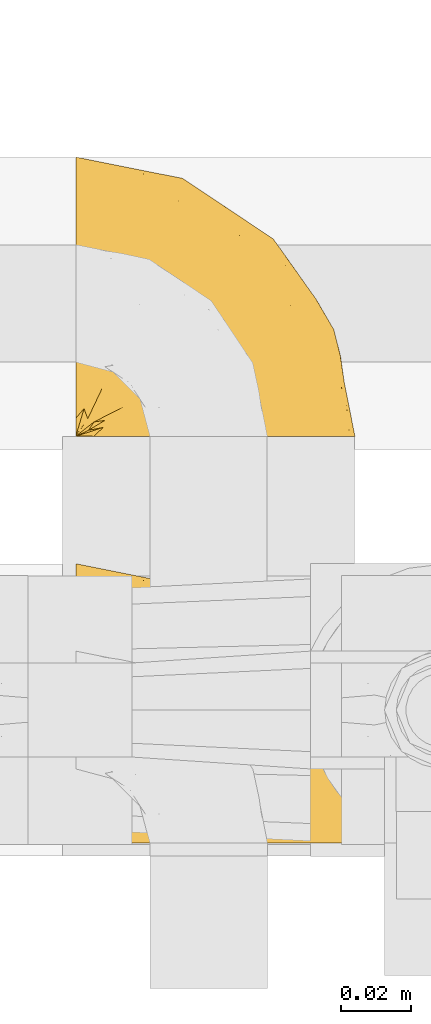
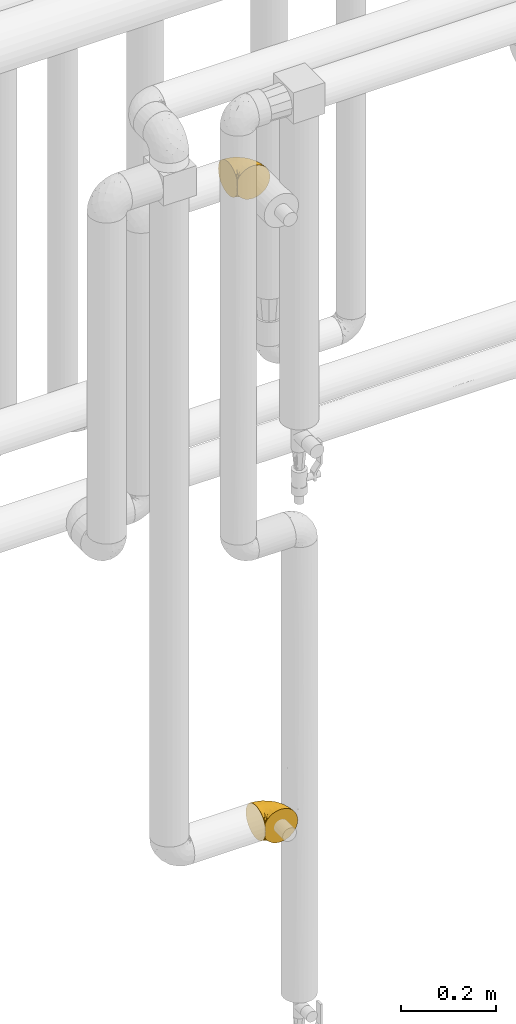
# One storey, part 447 of 827: 2 coverings.
"""IFC2X3 building model written with IfcOpenShell, lengths in millimetres."""

from ifc_helpers import new_model, entity, si_unit, converted_unit, derived_unit, direction, frame, origin, place, context, subcontext, project, spatial, faceted_brep, element, save


model = new_model("IFC2X3")

# Units and contexts
model_context = context("Model", 3, precision=0.01, world=origin(), true_north=direction((6.12303176911189e-17, 1.0)))
body_context = subcontext(model_context, "Body", "Model", "MODEL_VIEW")
ifc_project = project(units=[si_unit("LENGTHUNIT", "METRE", prefix="MILLI"), si_unit("AREAUNIT", "SQUARE_METRE"), si_unit("VOLUMEUNIT", "CUBIC_METRE"), converted_unit("PLANEANGLEUNIT", "DEGREE", entity("IfcRatioMeasure", 0.0174532925199433), si_unit("PLANEANGLEUNIT", "RADIAN"), dimensions=[0, 0, 0, 0, 0, 0, 0]), si_unit("MASSUNIT", "GRAM", prefix="KILO"), derived_unit("MASSDENSITYUNIT", [(si_unit("MASSUNIT", "GRAM", prefix="KILO"), 1), (si_unit("LENGTHUNIT", "METRE"), -3)]), derived_unit("MOMENTOFINERTIAUNIT", [(si_unit("LENGTHUNIT", "METRE"), 4)]), si_unit("TIMEUNIT", "SECOND"), si_unit("FREQUENCYUNIT", "HERTZ"), si_unit("THERMODYNAMICTEMPERATUREUNIT", "DEGREE_CELSIUS"), derived_unit("THERMALTRANSMITTANCEUNIT", [(si_unit("MASSUNIT", "GRAM", prefix="KILO"), 1), (si_unit("THERMODYNAMICTEMPERATUREUNIT", "KELVIN"), -1), (si_unit("TIMEUNIT", "SECOND"), -3)]), derived_unit("VOLUMETRICFLOWRATEUNIT", [(si_unit("LENGTHUNIT", "METRE"), 3), (si_unit("TIMEUNIT", "SECOND"), -1)]), derived_unit("MASSFLOWRATEUNIT", [(si_unit("MASSUNIT", "GRAM", prefix="KILO"), 1), (si_unit("TIMEUNIT", "SECOND"), -1)]), derived_unit("ROTATIONALFREQUENCYUNIT", [(si_unit("TIMEUNIT", "SECOND"), -1)]), si_unit("ELECTRICCURRENTUNIT", "AMPERE"), si_unit("ELECTRICVOLTAGEUNIT", "VOLT"), si_unit("POWERUNIT", "WATT"), si_unit("FORCEUNIT", "NEWTON", prefix="KILO"), si_unit("ILLUMINANCEUNIT", "LUX"), si_unit("LUMINOUSFLUXUNIT", "LUMEN"), si_unit("LUMINOUSINTENSITYUNIT", "CANDELA"), derived_unit("USERDEFINED", [(si_unit("MASSUNIT", "GRAM", prefix="KILO"), -1), (si_unit("LENGTHUNIT", "METRE"), -2), (si_unit("TIMEUNIT", "SECOND"), 3), (si_unit("LUMINOUSFLUXUNIT", "LUMEN"), 1)]), derived_unit("LINEARVELOCITYUNIT", [(si_unit("LENGTHUNIT", "METRE"), 1), (si_unit("TIMEUNIT", "SECOND"), -1)]), si_unit("PRESSUREUNIT", "PASCAL"), derived_unit("USERDEFINED", [(si_unit("LENGTHUNIT", "METRE"), -2), (si_unit("MASSUNIT", "GRAM", prefix="KILO"), 1), (si_unit("TIMEUNIT", "SECOND"), -2)]), derived_unit("LINEARFORCEUNIT", [(si_unit("MASSUNIT", "GRAM", prefix="KILO"), 1), (si_unit("LENGTHUNIT", "METRE"), 1), (si_unit("TIMEUNIT", "SECOND"), -2), (si_unit("LENGTHUNIT", "METRE"), -1)]), derived_unit("PLANARFORCEUNIT", [(si_unit("MASSUNIT", "GRAM", prefix="KILO"), 1), (si_unit("LENGTHUNIT", "METRE"), 1), (si_unit("TIMEUNIT", "SECOND"), -2), (si_unit("LENGTHUNIT", "METRE"), -2)])], contexts=[model_context])

# Site, building, storey
site_placement = place(None, origin())
site = spatial("IfcSite", under=ifc_project, at=site_placement, CompositionType="ELEMENT")
building_placement = place(site_placement, origin())
building = spatial("IfcBuilding", under=site, at=building_placement, CompositionType="ELEMENT")
storey_placement = place(building_placement, frame((0.0, 0.0, 28200.0)))
storey = spatial("IfcBuildingStorey", under=building, at=storey_placement, Name="08", CompositionType="ELEMENT", Elevation=28200.0)

# Coverings
covering_1_placement = place(storey_placement, frame((59233.76, 15520.93, 2407.08)))
element("IfcCovering", 1, at=covering_1_placement, inside=storey, Name=":ADSK_", ObjectType=":ADSK_", PredefinedType="INSULATION", context=body_context, shape_type="Brep", body=[
    faceted_brep([(1.6, 57.76, 81.15), (1.6, 65.69, 76.16), (1.6, 72.32, 69.53), (1.6, 77.3, 61.6), (1.6, 80.4, 52.75), (1.6, 81.45, 43.45), (1.6, 80.39, 34.13), (1.6, 77.3, 25.28), (1.6, 72.31, 17.35), (1.6, 65.68, 10.72), (1.6, 57.75, 5.74), (1.6, 48.9, 2.64), (1.6, 39.6, 1.6), (1.6, 30.22, 2.66), (1.6, 21.33, 5.79), (1.6, 13.37, 10.83), (1.6, 6.73, 17.53), (1.6, 1.77, 25.53), (1.6, 1.77, 26.45), (1.6, 1.77, 27.37), (1.6, 1.77, 28.17), (1.6, 1.77, 29.49), (1.6, 1.77, 30.81), (1.6, 1.77, 32.13), (1.6, 1.77, 33.45), (1.6, 1.77, 34.78), (1.6, 1.77, 36.1), (1.6, 1.77, 37.42), (1.6, 1.77, 38.74), (1.6, 1.77, 40.06), (1.6, 1.77, 41.38), (1.6, 1.77, 42.7), (1.6, 1.77, 44.02), (1.6, 1.77, 45.34), (1.6, 1.77, 46.66), (1.6, 1.77, 47.58), (1.6, 1.77, 48.5), (1.6, 1.77, 49.41), (1.6, 1.77, 50.33), (1.6, 1.77, 51.25), (1.6, 1.77, 52.17), (1.6, 1.77, 53.09), (1.6, 1.77, 54.01), (1.6, 1.77, 54.93), (1.6, 1.77, 55.85), (1.6, 1.77, 56.76), (1.6, 1.77, 57.68), (1.6, 1.77, 58.6), (1.6, 1.77, 59.52), (1.6, 1.77, 60.44), (1.6, 1.77, 61.36), (1.6, 6.74, 69.37), (1.6, 13.38, 76.07), (1.6, 21.35, 81.11), (1.6, 30.24, 84.24), (1.6, 39.6, 85.3), (1.6, 48.91, 84.24), (6.74, 1.6, 17.52), (13.37, 1.6, 10.83), (21.34, 1.6, 5.79), (30.23, 1.6, 2.66), (39.6, 1.6, 1.6), (50.43, 1.6, 3.02), (60.52, 1.6, 7.2), (69.19, 1.6, 13.85), (75.84, 1.6, 22.52), (80.02, 1.6, 32.61), (81.45, 1.6, 43.45), (80.02, 1.6, 54.28), (75.84, 1.6, 64.37), (69.19, 1.6, 73.04), (60.52, 1.6, 79.69), (50.43, 1.6, 83.87), (39.6, 1.6, 85.3), (30.23, 1.6, 84.23), (21.34, 1.6, 81.1), (13.37, 1.6, 76.06), (6.74, 1.6, 69.37), (1.77, 1.6, 61.36), (1.77, 1.6, 60.44), (1.77, 1.6, 59.12), (1.77, 1.6, 58.0), (1.77, 1.6, 56.88), (1.77, 1.6, 55.76), (1.77, 1.6, 54.64), (1.77, 1.6, 53.52), (1.77, 1.6, 52.4), (1.77, 1.6, 51.28), (1.77, 1.6, 50.16), (1.77, 1.6, 49.04), (1.77, 1.6, 47.92), (1.77, 1.6, 46.8), (1.77, 1.6, 45.68), (1.77, 1.6, 44.56), (1.77, 1.6, 43.45), (1.77, 1.6, 42.12), (1.77, 1.6, 40.8), (1.77, 1.6, 39.48), (1.77, 1.6, 38.16), (1.77, 1.6, 36.84), (1.77, 1.6, 35.52), (1.77, 1.6, 34.2), (1.77, 1.6, 32.88), (1.77, 1.6, 31.96), (1.77, 1.6, 31.05), (1.77, 1.6, 30.13), (1.77, 1.6, 29.21), (1.77, 1.6, 28.29), (1.77, 1.6, 27.37), (1.77, 1.6, 26.45), (1.77, 1.6, 25.53), (1.73, 1.71, 54.08), (1.72, 1.73, 55.16), (1.73, 1.71, 36.18), (1.72, 1.72, 35.13), (1.73, 1.71, 44.01), (1.73, 1.72, 45.08), (1.72, 1.72, 61.36), (1.72, 1.72, 59.98), (1.72, 1.72, 46.18), (1.72, 1.72, 26.74), (1.72, 1.72, 47.36), (1.73, 1.72, 29.67), (1.74, 1.7, 28.72), (1.72, 1.72, 39.77), (1.71, 1.73, 52.96), (1.73, 1.72, 51.84), (1.71, 1.73, 40.8), (1.72, 1.73, 41.87), (1.73, 1.72, 42.94), (1.72, 1.72, 27.77), (1.73, 1.71, 48.4), (1.72, 1.72, 37.21), (1.73, 1.71, 33.54), (1.72, 1.72, 32.49), (1.72, 1.72, 30.69), (1.72, 1.72, 50.69), (1.71, 1.73, 49.6), (1.72, 1.72, 56.32), (1.73, 1.71, 57.44), (1.71, 1.73, 58.88), (1.72, 1.72, 25.53), (1.68, 1.74, 61.36), (1.64, 1.75, 61.36), (1.64, 1.75, 25.53), (1.68, 1.74, 25.53), (1.75, 1.64, 61.36), (1.74, 1.68, 61.36), (1.74, 1.68, 25.53), (1.75, 1.64, 25.53), (1.7, 1.74, 31.59), (1.73, 1.71, 38.71), (24.54, 8.98, 3.97), (11.1, 37.05, 1.6), (8.47, 24.69, 3.97), (9.11, 15.28, 8.09), (4.86, 16.86, 8.09), (5.0, 6.58, 16.43), (6.81, 5.71, 15.73), (37.05, 11.1, 1.6), (9.03, 10.79, 10.79), (9.47, 4.13, 13.99), (16.39, 6.62, 8.08), (3.95, 9.52, 14.0), (9.9, 6.14, 12.83), (22.7, 17.79, 3.18), (34.5, 20.6, 1.6), (37.68, 8.73, 1.6), (15.82, 23.66, 3.28), (20.6, 34.5, 1.6), (14.37, 15.32, 6.28), (27.55, 27.55, 1.6), (5.2, 3.31, 19.06), (14.88, 9.81, 8.08), (8.73, 37.68, 1.6), (44.27, 67.23, 32.11), (20.94, 76.64, 29.62), (32.15, 75.37, 43.45), (46.13, 14.58, 2.45), (42.67, 23.71, 2.5), (55.18, 34.34, 9.73), (67.27, 29.1, 17.97), (62.91, 18.02, 10.24), (51.5, 22.27, 4.78), (54.79, 10.97, 4.78), (25.78, 56.79, 8.01), (13.05, 60.76, 8.01), (18.46, 67.04, 13.85), (32.4, 36.11, 2.42), (31.07, 68.85, 21.17), (77.32, 24.58, 35.73), (75.62, 21.54, 27.43), (16.9, 78.4, 43.45), (71.69, 14.11, 17.97), (61.4, 53.42, 35.71), (54.47, 58.19, 29.47), (27.66, 44.49, 3.41), (14.53, 51.77, 3.94), (15.56, 73.69, 21.17), (42.26, 45.89, 7.92), (41.51, 35.97, 4.25), (36.93, 56.55, 11.75), (42.72, 60.03, 18.31), (44.68, 63.64, 24.94), (71.2, 34.98, 28.78), (70.48, 40.58, 35.82), (75.37, 32.15, 43.45), (63.65, 47.26, 28.38), (58.06, 58.06, 43.45), (45.11, 66.71, 43.45), (78.4, 16.9, 43.45), (54.95, 52.08, 21.21), (59.31, 41.21, 16.48), (49.01, 49.76, 13.85), (66.71, 45.11, 43.45), (53.75, 15.65, 82.11), (77.27, 24.57, 51.41), (61.6, 50.54, 57.45), (44.24, 67.25, 54.78), (18.46, 67.06, 73.03), (15.55, 73.7, 65.7), (60.14, 26.13, 76.65), (70.5, 19.54, 68.92), (63.0, 38.96, 68.01), (25.78, 56.8, 78.88), (13.05, 60.77, 78.88), (14.53, 51.78, 82.94), (48.5, 59.09, 64.44), (44.23, 19.25, 84.49), (34.5, 20.6, 85.3), (37.05, 11.1, 85.3), (8.73, 37.68, 85.3), (77.68, 15.21, 57.84), (64.08, 12.76, 76.65), (70.25, 40.93, 51.19), (20.93, 76.65, 57.26), (49.9, 39.5, 78.14), (49.6, 25.01, 82.35), (31.06, 68.86, 65.7), (39.62, 26.7, 84.61), (34.42, 34.95, 84.36), (20.6, 34.5, 85.3), (27.55, 27.55, 85.3), (33.36, 61.27, 73.03), (27.68, 44.5, 83.48), (11.1, 37.05, 85.3), (46.67, 10.25, 84.54), (49.0, 49.78, 73.03), (38.94, 47.51, 79.54), (73.05, 29.38, 59.46), (56.63, 40.01, 73.5), (43.85, 33.36, 82.57), (24.54, 8.98, 82.92), (15.82, 23.67, 83.62), (8.47, 24.71, 82.92), (9.12, 15.29, 78.81), (9.47, 4.13, 72.9), (9.91, 6.14, 74.06), (16.85, 4.96, 78.81), (14.88, 9.81, 78.81), (5.2, 3.31, 67.83), (6.81, 5.7, 71.15), (3.96, 9.53, 72.91), (5.0, 6.59, 70.47), (5.86, 16.63, 78.81), (14.38, 15.34, 80.62), (9.04, 10.8, 76.11), (22.7, 17.79, 83.71)], [[[0, 1, 2, 3, 4, 5, 6, 7, 8, 9, 10, 11, 12, 13, 14, 15, 16, 17, 18, 19, 20, 21, 22, 23, 24, 25, 26, 27, 28, 29, 30, 31, 32, 33, 34, 35, 36, 37, 38, 39, 40, 41, 42, 43, 44, 45, 46, 47, 48, 49, 50, 51, 52, 53, 54, 55, 56]], [[57, 58, 59, 60, 61, 62, 63, 64, 65, 66, 67, 68, 69, 70, 71, 72, 73, 74, 75, 76, 77, 78, 79, 80, 81, 82, 83, 84, 85, 86, 87, 88, 89, 90, 91, 92, 93, 94, 95, 96, 97, 98, 99, 100, 101, 102, 103, 104, 105, 106, 107, 108, 109, 110]], [[111, 84, 112]], [[113, 26, 114]], [[114, 101, 100]], [[115, 93, 116]], [[79, 117, 118]], [[33, 116, 119]], [[117, 49, 118]], [[19, 18, 120]], [[119, 121, 34]], [[122, 21, 123]], [[97, 96, 124]], [[86, 125, 126]], [[116, 92, 119]], [[127, 96, 128]], [[32, 129, 115]], [[19, 120, 130]], [[121, 90, 131]], [[94, 115, 129]], [[115, 116, 32]], [[118, 49, 48]], [[113, 99, 132]], [[133, 114, 25]], [[24, 134, 133]], [[135, 22, 122]], [[136, 137, 88]], [[84, 83, 112]], [[138, 82, 139]], [[130, 20, 19]], [[118, 48, 140]], [[81, 140, 139]], [[123, 21, 20]], [[141, 120, 18]], [[139, 82, 81]], [[130, 107, 123]], [[49, 117, 142, 143, 50]], [[18, 17, 144, 145, 141]], [[79, 78, 146, 147, 117]], [[109, 141, 148, 149, 110]], [[102, 133, 134]], [[105, 135, 122]], [[118, 80, 79]], [[80, 118, 140]], [[120, 109, 108]], [[47, 46, 140, 48]], [[81, 80, 140]], [[44, 112, 138]], [[93, 115, 94]], [[46, 139, 140]], [[46, 45, 139]], [[139, 45, 138]], [[138, 112, 83]], [[85, 84, 111]], [[112, 43, 111]], [[83, 82, 138]], [[106, 122, 123]], [[105, 122, 106]], [[21, 122, 22]], [[124, 29, 28]], [[33, 32, 116]], [[128, 129, 31]], [[32, 31, 129]], [[34, 33, 119]], [[116, 93, 92]], [[129, 95, 94]], [[95, 129, 128]], [[41, 40, 125, 42]], [[119, 91, 121]], [[36, 35, 131, 37]], [[137, 131, 89]], [[121, 131, 35]], [[90, 121, 91]], [[119, 92, 91]], [[136, 126, 39]], [[125, 86, 85]], [[42, 125, 111]], [[85, 111, 125]], [[150, 23, 22]], [[130, 108, 107]], [[130, 123, 20]], [[107, 106, 123]], [[137, 37, 131]], [[136, 38, 137]], [[89, 88, 137]], [[131, 90, 89]], [[124, 151, 97]], [[40, 39, 126]], [[87, 126, 136]], [[86, 126, 87]], [[136, 88, 87]], [[40, 126, 125]], [[39, 38, 136]], [[95, 128, 96]], [[30, 128, 31]], [[29, 124, 127]], [[127, 128, 30]], [[151, 124, 28]], [[127, 30, 29]], [[127, 124, 96]], [[151, 98, 97]], [[45, 44, 138]], [[26, 113, 132]], [[113, 100, 99]], [[132, 151, 27]], [[27, 26, 132]], [[26, 25, 114]], [[100, 113, 114]], [[101, 133, 102]], [[133, 101, 114]], [[28, 27, 151]], [[132, 99, 98]], [[23, 134, 24]], [[25, 24, 133]], [[134, 23, 150]], [[135, 104, 150]], [[150, 104, 103]], [[103, 102, 134]], [[130, 120, 108]], [[109, 120, 141]], [[42, 111, 43]], [[112, 44, 43]], [[104, 135, 105]], [[134, 150, 103]], [[135, 150, 22]], [[35, 34, 121]], [[137, 38, 37]], [[98, 151, 132]], [[59, 152, 60]], [[13, 153, 154]], [[155, 156, 154]], [[157, 158, 141]], [[159, 60, 152]], [[160, 157, 155]], [[161, 162, 58]], [[58, 162, 59]], [[144, 16, 163]], [[58, 57, 161]], [[162, 161, 164]], [[157, 163, 155]], [[163, 16, 15]], [[57, 149, 161]], [[152, 165, 166]], [[157, 144, 163]], [[60, 159, 167, 61]], [[156, 14, 154]], [[163, 156, 155]], [[155, 154, 168]], [[168, 154, 169]], [[155, 170, 160]], [[57, 110, 149]], [[144, 17, 16]], [[156, 15, 14]], [[171, 165, 168]], [[158, 164, 172]], [[14, 13, 154]], [[157, 141, 145, 144]], [[173, 164, 158]], [[173, 160, 170]], [[171, 166, 165]], [[168, 165, 170]], [[168, 169, 171]], [[152, 173, 165]], [[170, 155, 168]], [[165, 173, 170]], [[160, 173, 158]], [[172, 149, 148]], [[148, 141, 158]], [[158, 157, 160]], [[152, 166, 159]], [[173, 152, 162]], [[59, 162, 152]], [[13, 12, 174, 153]], [[153, 169, 154]], [[15, 156, 163]], [[162, 164, 173]], [[172, 164, 161]], [[149, 172, 161]], [[158, 172, 148]], [[175, 176, 177]], [[178, 166, 179]], [[180, 181, 182]], [[183, 184, 178]], [[185, 186, 187]], [[171, 188, 179]], [[174, 12, 11]], [[189, 176, 175]], [[190, 66, 191]], [[176, 6, 192]], [[193, 65, 64]], [[63, 184, 182]], [[63, 182, 64]], [[65, 193, 191]], [[184, 63, 62]], [[175, 194, 195]], [[196, 169, 197]], [[174, 11, 197]], [[8, 7, 198]], [[187, 9, 8]], [[197, 169, 153, 174]], [[197, 11, 10]], [[186, 197, 10]], [[199, 180, 200]], [[197, 185, 196]], [[201, 189, 202]], [[201, 187, 189]], [[195, 203, 175]], [[191, 204, 190]], [[176, 7, 6]], [[177, 176, 192]], [[189, 198, 176]], [[65, 191, 66]], [[198, 187, 8]], [[205, 206, 190]], [[9, 186, 10]], [[181, 207, 204]], [[208, 175, 177, 209]], [[66, 190, 210]], [[211, 212, 213]], [[190, 204, 205]], [[180, 182, 183]], [[193, 182, 181]], [[62, 61, 167]], [[196, 185, 199]], [[196, 200, 188]], [[6, 5, 192]], [[176, 198, 7]], [[187, 198, 189]], [[187, 186, 9]], [[197, 186, 185]], [[200, 180, 183]], [[180, 213, 212]], [[179, 183, 178]], [[185, 201, 199]], [[210, 190, 206]], [[210, 67, 66]], [[205, 204, 207]], [[194, 205, 207]], [[194, 214, 205]], [[195, 194, 207]], [[208, 194, 175]], [[207, 211, 195]], [[202, 203, 211]], [[212, 207, 181]], [[202, 211, 213]], [[201, 202, 213]], [[189, 175, 203]], [[199, 201, 213]], [[187, 201, 185]], [[180, 199, 213]], [[196, 199, 200]], [[211, 203, 195]], [[189, 203, 202]], [[207, 212, 211]], [[180, 212, 181]], [[214, 194, 208]], [[214, 206, 205]], [[196, 188, 169]], [[181, 204, 191]], [[182, 193, 64]], [[191, 193, 181]], [[178, 62, 167]], [[182, 184, 183]], [[62, 178, 184]], [[178, 167, 159, 166]], [[171, 179, 166]], [[200, 183, 179]], [[179, 188, 200]], [[169, 188, 171]], [[71, 215, 72]], [[206, 216, 210]], [[217, 208, 218]], [[216, 68, 210]], [[219, 220, 2]], [[221, 222, 223]], [[224, 225, 226]], [[227, 223, 217]], [[228, 229, 230]], [[56, 231, 226]], [[232, 222, 69]], [[56, 55, 231]], [[70, 233, 71]], [[71, 233, 215]], [[0, 56, 226]], [[208, 217, 234]], [[218, 177, 235]], [[221, 236, 237]], [[238, 220, 219]], [[1, 219, 2]], [[68, 216, 232]], [[235, 3, 220]], [[235, 192, 4]], [[1, 0, 225]], [[228, 239, 229]], [[240, 241, 242]], [[243, 238, 219]], [[224, 226, 244]], [[226, 241, 244]], [[3, 235, 4]], [[69, 222, 70]], [[225, 219, 1]], [[218, 235, 238]], [[243, 219, 224]], [[218, 227, 217]], [[3, 2, 220]], [[218, 208, 209, 177]], [[226, 231, 245, 241]], [[215, 228, 246]], [[247, 248, 236]], [[248, 224, 244]], [[223, 222, 249]], [[233, 222, 221]], [[242, 239, 240]], [[248, 247, 243]], [[217, 223, 249]], [[250, 247, 236]], [[216, 234, 249]], [[218, 238, 227]], [[192, 235, 177]], [[192, 5, 4]], [[72, 246, 73]], [[235, 220, 238]], [[226, 225, 0]], [[219, 225, 224]], [[240, 248, 244]], [[239, 242, 229]], [[236, 248, 251]], [[68, 67, 210]], [[234, 216, 206]], [[216, 249, 232]], [[234, 206, 214, 208]], [[249, 234, 217]], [[222, 232, 249]], [[69, 68, 232]], [[246, 228, 230]], [[237, 228, 215]], [[243, 227, 238]], [[223, 227, 247]], [[73, 246, 230]], [[215, 246, 72]], [[248, 243, 224]], [[227, 243, 247]], [[237, 236, 251]], [[250, 221, 223]], [[222, 233, 70]], [[215, 233, 221]], [[221, 237, 215]], [[239, 237, 251]], [[237, 239, 228]], [[239, 251, 240]], [[248, 240, 251]], [[241, 240, 244]], [[221, 250, 236]], [[223, 247, 250]], [[74, 230, 252]], [[253, 254, 255]], [[146, 77, 256]], [[257, 258, 259]], [[260, 256, 257]], [[260, 261, 147]], [[75, 74, 252]], [[51, 143, 262]], [[263, 143, 142, 117]], [[256, 77, 76]], [[252, 258, 75]], [[253, 241, 254]], [[254, 245, 54]], [[258, 256, 76]], [[53, 52, 264]], [[255, 265, 253]], [[254, 264, 255]], [[255, 264, 262]], [[75, 258, 76]], [[265, 255, 266]], [[255, 262, 263]], [[51, 50, 143]], [[54, 245, 231, 55]], [[51, 262, 52]], [[253, 267, 242]], [[254, 54, 53]], [[266, 259, 265]], [[146, 78, 77]], [[263, 117, 261]], [[146, 256, 260]], [[257, 259, 261]], [[267, 253, 265]], [[229, 267, 252]], [[242, 267, 229]], [[242, 241, 253]], [[252, 267, 259]], [[255, 263, 266]], [[259, 267, 265]], [[261, 117, 147]], [[263, 261, 266]], [[259, 266, 261]], [[230, 74, 73]], [[230, 229, 252]], [[259, 258, 252]], [[254, 241, 245]], [[53, 264, 254]], [[52, 262, 264]], [[143, 263, 262]], [[258, 257, 256]], [[261, 260, 257]], [[146, 260, 147]]]),
])
covering_2_placement = place(storey_placement, frame((59233.76, 15404.61, 827.07)))
element("IfcCovering", 2, at=covering_2_placement, inside=storey, Name=":ADSK_", ObjectType=":ADSK_", PredefinedType="INSULATION", context=body_context, shape_type="Brep", body=[
    faceted_brep([(1.6, 57.76, 81.15), (1.6, 65.69, 76.16), (1.6, 72.32, 69.53), (1.6, 77.3, 61.6), (1.6, 80.4, 52.75), (1.6, 81.45, 43.45), (1.6, 80.39, 34.13), (1.6, 77.3, 25.28), (1.6, 72.31, 17.35), (1.6, 65.68, 10.72), (1.6, 57.75, 5.74), (1.6, 48.9, 2.64), (1.6, 39.6, 1.6), (1.6, 30.22, 2.66), (1.6, 21.33, 5.79), (1.6, 13.37, 10.83), (1.6, 6.73, 17.53), (1.6, 1.77, 25.53), (1.6, 1.77, 26.45), (1.6, 1.77, 27.37), (1.6, 1.77, 28.17), (1.6, 1.77, 29.49), (1.6, 1.77, 30.81), (1.6, 1.77, 32.13), (1.6, 1.77, 33.45), (1.6, 1.77, 34.78), (1.6, 1.77, 36.1), (1.6, 1.77, 37.42), (1.6, 1.77, 38.74), (1.6, 1.77, 40.06), (1.6, 1.77, 41.38), (1.6, 1.77, 42.7), (1.6, 1.77, 44.02), (1.6, 1.77, 45.34), (1.6, 1.77, 46.66), (1.6, 1.77, 47.58), (1.6, 1.77, 48.5), (1.6, 1.77, 49.41), (1.6, 1.77, 50.33), (1.6, 1.77, 51.25), (1.6, 1.77, 52.17), (1.6, 1.77, 53.09), (1.6, 1.77, 54.01), (1.6, 1.77, 54.93), (1.6, 1.77, 55.85), (1.6, 1.77, 56.76), (1.6, 1.77, 57.68), (1.6, 1.77, 58.6), (1.6, 1.77, 59.52), (1.6, 1.77, 60.44), (1.6, 1.77, 61.36), (1.6, 6.74, 69.37), (1.6, 13.38, 76.07), (1.6, 21.35, 81.11), (1.6, 30.24, 84.24), (1.6, 39.6, 85.3), (1.6, 48.91, 84.24), (6.74, 1.6, 17.52), (13.37, 1.6, 10.83), (21.34, 1.6, 5.79), (30.23, 1.6, 2.66), (39.6, 1.6, 1.6), (50.43, 1.6, 3.02), (60.52, 1.6, 7.2), (69.19, 1.6, 13.85), (75.84, 1.6, 22.52), (80.02, 1.6, 32.61), (81.45, 1.6, 43.45), (80.02, 1.6, 54.28), (75.84, 1.6, 64.37), (69.19, 1.6, 73.04), (60.52, 1.6, 79.69), (50.43, 1.6, 83.87), (39.6, 1.6, 85.3), (30.23, 1.6, 84.23), (21.34, 1.6, 81.1), (13.37, 1.6, 76.06), (6.74, 1.6, 69.37), (1.77, 1.6, 61.36), (1.77, 1.6, 60.44), (1.77, 1.6, 59.12), (1.77, 1.6, 58.0), (1.77, 1.6, 56.88), (1.77, 1.6, 55.76), (1.77, 1.6, 54.64), (1.77, 1.6, 53.52), (1.77, 1.6, 52.4), (1.77, 1.6, 51.28), (1.77, 1.6, 50.16), (1.77, 1.6, 49.04), (1.77, 1.6, 47.92), (1.77, 1.6, 46.8), (1.77, 1.6, 45.68), (1.77, 1.6, 44.56), (1.77, 1.6, 43.45), (1.77, 1.6, 42.12), (1.77, 1.6, 40.8), (1.77, 1.6, 39.48), (1.77, 1.6, 38.16), (1.77, 1.6, 36.84), (1.77, 1.6, 35.52), (1.77, 1.6, 34.2), (1.77, 1.6, 32.88), (1.77, 1.6, 31.96), (1.77, 1.6, 31.05), (1.77, 1.6, 30.13), (1.77, 1.6, 29.21), (1.77, 1.6, 28.29), (1.77, 1.6, 27.37), (1.77, 1.6, 26.45), (1.77, 1.6, 25.53), (1.73, 1.71, 54.08), (1.72, 1.73, 55.16), (1.73, 1.71, 36.18), (1.72, 1.72, 35.13), (1.73, 1.71, 44.01), (1.73, 1.72, 45.08), (1.72, 1.72, 61.36), (1.72, 1.72, 59.98), (1.72, 1.72, 46.18), (1.72, 1.72, 26.74), (1.72, 1.72, 47.36), (1.73, 1.72, 29.67), (1.74, 1.7, 28.72), (1.72, 1.72, 39.77), (1.71, 1.73, 52.96), (1.73, 1.72, 51.84), (1.71, 1.73, 40.8), (1.72, 1.73, 41.87), (1.73, 1.72, 42.94), (1.72, 1.72, 27.77), (1.73, 1.71, 48.4), (1.72, 1.72, 37.21), (1.73, 1.71, 33.54), (1.72, 1.72, 32.49), (1.72, 1.72, 30.69), (1.72, 1.72, 50.69), (1.71, 1.73, 49.6), (1.72, 1.72, 56.32), (1.73, 1.71, 57.44), (1.71, 1.73, 58.88), (1.72, 1.72, 25.53), (1.68, 1.74, 61.36), (1.64, 1.75, 61.36), (1.64, 1.75, 25.53), (1.68, 1.74, 25.53), (1.75, 1.64, 61.36), (1.74, 1.68, 61.36), (1.74, 1.68, 25.53), (1.75, 1.64, 25.53), (1.7, 1.74, 31.59), (1.73, 1.71, 38.71), (24.54, 8.98, 3.97), (11.1, 37.05, 1.6), (8.47, 24.69, 3.97), (9.11, 15.28, 8.09), (4.86, 16.86, 8.09), (5.0, 6.58, 16.43), (6.81, 5.71, 15.73), (37.05, 11.1, 1.6), (9.03, 10.79, 10.79), (9.47, 4.13, 13.99), (16.39, 6.62, 8.08), (3.95, 9.52, 14.0), (9.9, 6.14, 12.83), (22.7, 17.79, 3.18), (34.5, 20.6, 1.6), (37.68, 8.73, 1.6), (15.82, 23.66, 3.28), (20.6, 34.5, 1.6), (14.37, 15.32, 6.28), (27.55, 27.55, 1.6), (5.2, 3.31, 19.06), (14.88, 9.81, 8.08), (8.73, 37.68, 1.6), (44.27, 67.23, 32.11), (20.94, 76.64, 29.62), (32.15, 75.37, 43.45), (46.13, 14.58, 2.45), (42.67, 23.71, 2.5), (55.18, 34.34, 9.73), (67.27, 29.1, 17.97), (62.91, 18.02, 10.24), (51.5, 22.27, 4.78), (54.79, 10.97, 4.78), (25.78, 56.79, 8.01), (13.05, 60.76, 8.01), (18.46, 67.04, 13.85), (32.4, 36.11, 2.42), (31.07, 68.85, 21.17), (77.32, 24.58, 35.73), (75.62, 21.54, 27.43), (16.9, 78.4, 43.45), (71.69, 14.11, 17.97), (61.4, 53.42, 35.71), (54.47, 58.19, 29.47), (27.66, 44.49, 3.41), (14.53, 51.77, 3.94), (15.56, 73.69, 21.17), (42.26, 45.89, 7.92), (41.51, 35.97, 4.25), (36.93, 56.55, 11.75), (42.72, 60.03, 18.31), (44.68, 63.64, 24.94), (71.2, 34.98, 28.78), (70.48, 40.58, 35.82), (75.37, 32.15, 43.45), (63.65, 47.26, 28.38), (58.06, 58.06, 43.45), (45.11, 66.71, 43.45), (78.4, 16.9, 43.45), (54.95, 52.08, 21.21), (59.31, 41.21, 16.48), (49.01, 49.76, 13.85), (66.71, 45.11, 43.45), (53.75, 15.65, 82.11), (77.27, 24.57, 51.41), (61.6, 50.54, 57.45), (44.24, 67.25, 54.78), (18.46, 67.06, 73.03), (15.55, 73.7, 65.7), (60.14, 26.13, 76.65), (70.5, 19.54, 68.92), (63.0, 38.96, 68.01), (25.78, 56.8, 78.88), (13.05, 60.77, 78.88), (14.53, 51.78, 82.94), (48.5, 59.09, 64.44), (44.23, 19.25, 84.49), (34.5, 20.6, 85.3), (37.05, 11.1, 85.3), (8.73, 37.68, 85.3), (77.68, 15.21, 57.84), (64.08, 12.76, 76.65), (70.25, 40.93, 51.19), (20.93, 76.65, 57.26), (49.9, 39.5, 78.14), (49.6, 25.01, 82.35), (31.06, 68.86, 65.7), (39.62, 26.7, 84.61), (34.42, 34.95, 84.36), (20.6, 34.5, 85.3), (27.55, 27.55, 85.3), (33.36, 61.27, 73.03), (27.68, 44.5, 83.48), (11.1, 37.05, 85.3), (46.67, 10.25, 84.54), (49.0, 49.78, 73.03), (38.94, 47.51, 79.54), (73.05, 29.38, 59.46), (56.63, 40.01, 73.5), (43.85, 33.36, 82.57), (24.54, 8.98, 82.92), (15.82, 23.67, 83.62), (8.47, 24.71, 82.92), (9.12, 15.29, 78.81), (9.47, 4.13, 72.9), (9.91, 6.14, 74.06), (16.85, 4.96, 78.81), (14.88, 9.81, 78.81), (5.2, 3.31, 67.83), (6.81, 5.7, 71.15), (3.96, 9.53, 72.91), (5.0, 6.59, 70.47), (5.86, 16.63, 78.81), (14.38, 15.34, 80.62), (9.04, 10.8, 76.11), (22.7, 17.79, 83.71)], [[[0, 1, 2, 3, 4, 5, 6, 7, 8, 9, 10, 11, 12, 13, 14, 15, 16, 17, 18, 19, 20, 21, 22, 23, 24, 25, 26, 27, 28, 29, 30, 31, 32, 33, 34, 35, 36, 37, 38, 39, 40, 41, 42, 43, 44, 45, 46, 47, 48, 49, 50, 51, 52, 53, 54, 55, 56]], [[57, 58, 59, 60, 61, 62, 63, 64, 65, 66, 67, 68, 69, 70, 71, 72, 73, 74, 75, 76, 77, 78, 79, 80, 81, 82, 83, 84, 85, 86, 87, 88, 89, 90, 91, 92, 93, 94, 95, 96, 97, 98, 99, 100, 101, 102, 103, 104, 105, 106, 107, 108, 109, 110]], [[111, 84, 112]], [[113, 26, 114]], [[114, 101, 100]], [[115, 93, 116]], [[79, 117, 118]], [[33, 116, 119]], [[117, 49, 118]], [[19, 18, 120]], [[119, 121, 34]], [[122, 21, 123]], [[97, 96, 124]], [[86, 125, 126]], [[116, 92, 119]], [[127, 96, 128]], [[32, 129, 115]], [[19, 120, 130]], [[121, 90, 131]], [[94, 115, 129]], [[115, 116, 32]], [[118, 49, 48]], [[113, 99, 132]], [[133, 114, 25]], [[24, 134, 133]], [[135, 22, 122]], [[136, 137, 88]], [[84, 83, 112]], [[138, 82, 139]], [[130, 20, 19]], [[118, 48, 140]], [[81, 140, 139]], [[123, 21, 20]], [[141, 120, 18]], [[139, 82, 81]], [[130, 107, 123]], [[49, 117, 142, 143, 50]], [[18, 17, 144, 145, 141]], [[79, 78, 146, 147, 117]], [[109, 141, 148, 149, 110]], [[102, 133, 134]], [[105, 135, 122]], [[118, 80, 79]], [[80, 118, 140]], [[120, 109, 108]], [[47, 46, 140, 48]], [[81, 80, 140]], [[44, 112, 138]], [[93, 115, 94]], [[46, 139, 140]], [[46, 45, 139]], [[139, 45, 138]], [[138, 112, 83]], [[85, 84, 111]], [[112, 43, 111]], [[83, 82, 138]], [[106, 122, 123]], [[105, 122, 106]], [[21, 122, 22]], [[124, 29, 28]], [[33, 32, 116]], [[128, 129, 31]], [[32, 31, 129]], [[34, 33, 119]], [[116, 93, 92]], [[129, 95, 94]], [[95, 129, 128]], [[41, 40, 125, 42]], [[119, 91, 121]], [[36, 35, 131, 37]], [[137, 131, 89]], [[121, 131, 35]], [[90, 121, 91]], [[119, 92, 91]], [[136, 126, 39]], [[125, 86, 85]], [[42, 125, 111]], [[85, 111, 125]], [[150, 23, 22]], [[130, 108, 107]], [[130, 123, 20]], [[107, 106, 123]], [[137, 37, 131]], [[136, 38, 137]], [[89, 88, 137]], [[131, 90, 89]], [[124, 151, 97]], [[40, 39, 126]], [[87, 126, 136]], [[86, 126, 87]], [[136, 88, 87]], [[40, 126, 125]], [[39, 38, 136]], [[95, 128, 96]], [[30, 128, 31]], [[29, 124, 127]], [[127, 128, 30]], [[151, 124, 28]], [[127, 30, 29]], [[127, 124, 96]], [[151, 98, 97]], [[45, 44, 138]], [[26, 113, 132]], [[113, 100, 99]], [[132, 151, 27]], [[27, 26, 132]], [[26, 25, 114]], [[100, 113, 114]], [[101, 133, 102]], [[133, 101, 114]], [[28, 27, 151]], [[132, 99, 98]], [[23, 134, 24]], [[25, 24, 133]], [[134, 23, 150]], [[135, 104, 150]], [[150, 104, 103]], [[103, 102, 134]], [[130, 120, 108]], [[109, 120, 141]], [[42, 111, 43]], [[112, 44, 43]], [[104, 135, 105]], [[134, 150, 103]], [[135, 150, 22]], [[35, 34, 121]], [[137, 38, 37]], [[98, 151, 132]], [[59, 152, 60]], [[13, 153, 154]], [[155, 156, 154]], [[157, 158, 141]], [[159, 60, 152]], [[160, 157, 155]], [[161, 162, 58]], [[58, 162, 59]], [[144, 16, 163]], [[58, 57, 161]], [[162, 161, 164]], [[157, 163, 155]], [[163, 16, 15]], [[57, 149, 161]], [[152, 165, 166]], [[157, 144, 163]], [[60, 159, 167, 61]], [[156, 14, 154]], [[163, 156, 155]], [[155, 154, 168]], [[168, 154, 169]], [[155, 170, 160]], [[57, 110, 149]], [[144, 17, 16]], [[156, 15, 14]], [[171, 165, 168]], [[158, 164, 172]], [[14, 13, 154]], [[157, 141, 145, 144]], [[173, 164, 158]], [[173, 160, 170]], [[171, 166, 165]], [[168, 165, 170]], [[168, 169, 171]], [[152, 173, 165]], [[170, 155, 168]], [[165, 173, 170]], [[160, 173, 158]], [[172, 149, 148]], [[148, 141, 158]], [[158, 157, 160]], [[152, 166, 159]], [[173, 152, 162]], [[59, 162, 152]], [[13, 12, 174, 153]], [[153, 169, 154]], [[15, 156, 163]], [[162, 164, 173]], [[172, 164, 161]], [[149, 172, 161]], [[158, 172, 148]], [[175, 176, 177]], [[178, 166, 179]], [[180, 181, 182]], [[183, 184, 178]], [[185, 186, 187]], [[171, 188, 179]], [[174, 12, 11]], [[189, 176, 175]], [[190, 66, 191]], [[176, 6, 192]], [[193, 65, 64]], [[63, 184, 182]], [[63, 182, 64]], [[65, 193, 191]], [[184, 63, 62]], [[175, 194, 195]], [[196, 169, 197]], [[174, 11, 197]], [[8, 7, 198]], [[187, 9, 8]], [[197, 169, 153, 174]], [[197, 11, 10]], [[186, 197, 10]], [[199, 180, 200]], [[197, 185, 196]], [[201, 189, 202]], [[201, 187, 189]], [[195, 203, 175]], [[191, 204, 190]], [[176, 7, 6]], [[177, 176, 192]], [[189, 198, 176]], [[65, 191, 66]], [[198, 187, 8]], [[205, 206, 190]], [[9, 186, 10]], [[181, 207, 204]], [[208, 175, 177, 209]], [[66, 190, 210]], [[211, 212, 213]], [[190, 204, 205]], [[180, 182, 183]], [[193, 182, 181]], [[62, 61, 167]], [[196, 185, 199]], [[196, 200, 188]], [[6, 5, 192]], [[176, 198, 7]], [[187, 198, 189]], [[187, 186, 9]], [[197, 186, 185]], [[200, 180, 183]], [[180, 213, 212]], [[179, 183, 178]], [[185, 201, 199]], [[210, 190, 206]], [[210, 67, 66]], [[205, 204, 207]], [[194, 205, 207]], [[194, 214, 205]], [[195, 194, 207]], [[208, 194, 175]], [[207, 211, 195]], [[202, 203, 211]], [[212, 207, 181]], [[202, 211, 213]], [[201, 202, 213]], [[189, 175, 203]], [[199, 201, 213]], [[187, 201, 185]], [[180, 199, 213]], [[196, 199, 200]], [[211, 203, 195]], [[189, 203, 202]], [[207, 212, 211]], [[180, 212, 181]], [[214, 194, 208]], [[214, 206, 205]], [[196, 188, 169]], [[181, 204, 191]], [[182, 193, 64]], [[191, 193, 181]], [[178, 62, 167]], [[182, 184, 183]], [[62, 178, 184]], [[178, 167, 159, 166]], [[171, 179, 166]], [[200, 183, 179]], [[179, 188, 200]], [[169, 188, 171]], [[71, 215, 72]], [[206, 216, 210]], [[217, 208, 218]], [[216, 68, 210]], [[219, 220, 2]], [[221, 222, 223]], [[224, 225, 226]], [[227, 223, 217]], [[228, 229, 230]], [[56, 231, 226]], [[232, 222, 69]], [[56, 55, 231]], [[70, 233, 71]], [[71, 233, 215]], [[0, 56, 226]], [[208, 217, 234]], [[218, 177, 235]], [[221, 236, 237]], [[238, 220, 219]], [[1, 219, 2]], [[68, 216, 232]], [[235, 3, 220]], [[235, 192, 4]], [[1, 0, 225]], [[228, 239, 229]], [[240, 241, 242]], [[243, 238, 219]], [[224, 226, 244]], [[226, 241, 244]], [[3, 235, 4]], [[69, 222, 70]], [[225, 219, 1]], [[218, 235, 238]], [[243, 219, 224]], [[218, 227, 217]], [[3, 2, 220]], [[218, 208, 209, 177]], [[226, 231, 245, 241]], [[215, 228, 246]], [[247, 248, 236]], [[248, 224, 244]], [[223, 222, 249]], [[233, 222, 221]], [[242, 239, 240]], [[248, 247, 243]], [[217, 223, 249]], [[250, 247, 236]], [[216, 234, 249]], [[218, 238, 227]], [[192, 235, 177]], [[192, 5, 4]], [[72, 246, 73]], [[235, 220, 238]], [[226, 225, 0]], [[219, 225, 224]], [[240, 248, 244]], [[239, 242, 229]], [[236, 248, 251]], [[68, 67, 210]], [[234, 216, 206]], [[216, 249, 232]], [[234, 206, 214, 208]], [[249, 234, 217]], [[222, 232, 249]], [[69, 68, 232]], [[246, 228, 230]], [[237, 228, 215]], [[243, 227, 238]], [[223, 227, 247]], [[73, 246, 230]], [[215, 246, 72]], [[248, 243, 224]], [[227, 243, 247]], [[237, 236, 251]], [[250, 221, 223]], [[222, 233, 70]], [[215, 233, 221]], [[221, 237, 215]], [[239, 237, 251]], [[237, 239, 228]], [[239, 251, 240]], [[248, 240, 251]], [[241, 240, 244]], [[221, 250, 236]], [[223, 247, 250]], [[74, 230, 252]], [[253, 254, 255]], [[146, 77, 256]], [[257, 258, 259]], [[260, 256, 257]], [[260, 261, 147]], [[75, 74, 252]], [[51, 143, 262]], [[263, 143, 142, 117]], [[256, 77, 76]], [[252, 258, 75]], [[253, 241, 254]], [[254, 245, 54]], [[258, 256, 76]], [[53, 52, 264]], [[255, 265, 253]], [[254, 264, 255]], [[255, 264, 262]], [[75, 258, 76]], [[265, 255, 266]], [[255, 262, 263]], [[51, 50, 143]], [[54, 245, 231, 55]], [[51, 262, 52]], [[253, 267, 242]], [[254, 54, 53]], [[266, 259, 265]], [[146, 78, 77]], [[263, 117, 261]], [[146, 256, 260]], [[257, 259, 261]], [[267, 253, 265]], [[229, 267, 252]], [[242, 267, 229]], [[242, 241, 253]], [[252, 267, 259]], [[255, 263, 266]], [[259, 267, 265]], [[261, 117, 147]], [[263, 261, 266]], [[259, 266, 261]], [[230, 74, 73]], [[230, 229, 252]], [[259, 258, 252]], [[254, 241, 245]], [[53, 264, 254]], [[52, 262, 264]], [[143, 263, 262]], [[258, 257, 256]], [[261, 260, 257]], [[146, 260, 147]]]),
])

save(model, "model.ifc")
